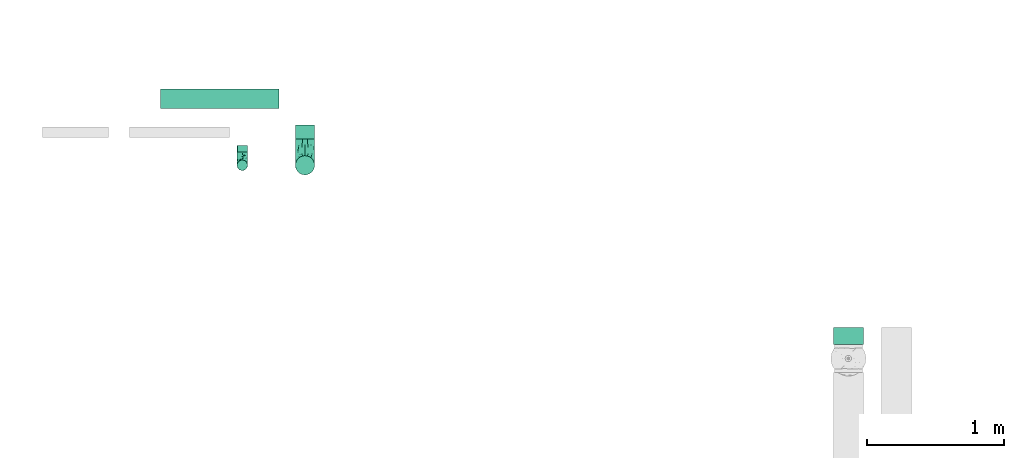
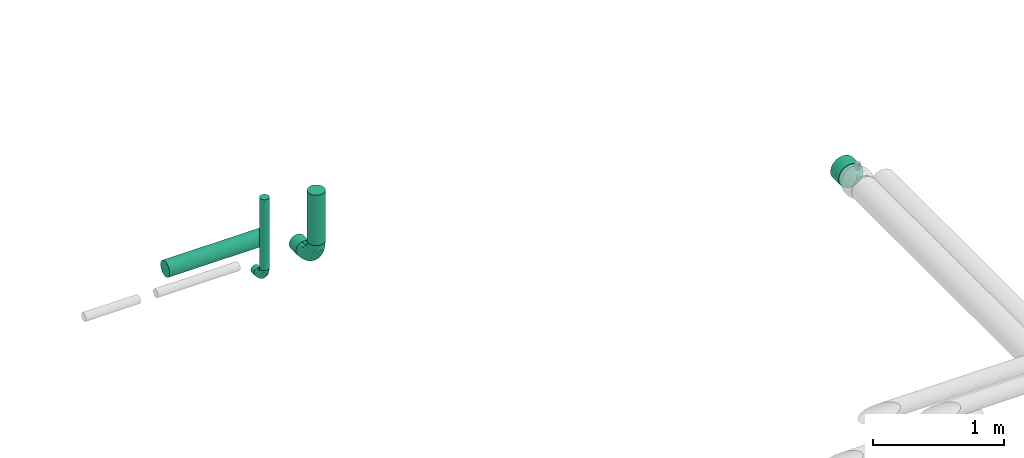
# One storey, part 2 of 6: 6 flow segments, 2 flow fittings.
"""IFC2X3 building model written with IfcOpenShell, lengths in millimetres."""

import ifcopenshell
import ifcopenshell.guid

model = None  # the IFC model being written
_history = None  # IfcOwnerHistory: only IFC2X3 demands one
_inside = {}  # id of a spatial element -> (the spatial element, [elements in it])
_under = {}  # id of a project, library or spatial element -> (it, [spatial elements below it])
_declared = {}  # id of a project -> (the project, [libraries it declares])
_typed = {}  # id of a type object -> (the type object, [elements of that type])
_made_of = {}  # id of a material, layer set ... -> (it, [elements and type objects made of it])


def new_model(schema):
    """Start an empty IFC model of exactly this schema.

    Asked for "IFC4X3", IfcOpenShell would pick the latest addendum, in which some entities
    have other attributes; the version numbers below select the first issue.
    IFC2X3 requires an IfcOwnerHistory on every rooted entity: one is made here for all.
    """
    global model, _history
    if schema == "IFC4X3":
        model = ifcopenshell.file(schema_version=(4, 3, 0, 0))
    else:
        model = ifcopenshell.file(schema=schema)
    _inside.clear()
    _under.clear()
    _declared.clear()
    _typed.clear()
    _made_of.clear()
    _history = None
    if model.schema == "IFC2X3":
        org = make("IfcOrganization", Name="unknown")
        user = make(
            "IfcPersonAndOrganization",
            ThePerson=make("IfcPerson", FamilyName="unknown"),
            TheOrganization=org,
        )
        app = make(
            "IfcApplication",
            ApplicationDeveloper=org,
            Version="unknown",
            ApplicationFullName="unknown",
            ApplicationIdentifier="unknown",
        )
        _history = make(
            "IfcOwnerHistory",
            OwningUser=user,
            OwningApplication=app,
            ChangeAction="ADDED",
            CreationDate=0,
        )
    return model


def make(cls, **values):
    """One entity of the class cls with the attributes given. An attribute that is None is left unset."""
    return model.create_entity(
        cls, **{name: value for name, value in values.items() if value is not None}
    )


def entity(cls, *values):
    """Any entity or typed value of the class cls, its attributes in the order of the schema. None: left unset."""
    e = model.create_entity(cls)
    for i, value in enumerate(values):
        if value is not None:
            e[i] = value
    return e


def rooted(cls, **values):
    """An entity with a GlobalId (a new one), such as an element, a storey or a relation."""
    return make(cls, GlobalId=ifcopenshell.guid.new(), OwnerHistory=_history, **values)


def si_unit(unit_type, name, prefix=None):
    """IfcSIUnit, for example si_unit("LENGTHUNIT", "METRE", prefix="MILLI")."""
    return make("IfcSIUnit", UnitType=unit_type, Prefix=prefix, Name=name)


def converted_unit(unit_type, name, factor, base, dimensions=None, offset=None):
    """IfcConversionBasedUnit, such as the inch: factor (a typed value) times the base unit."""
    return make(
        "IfcConversionBasedUnit"
        if offset is None
        else "IfcConversionBasedUnitWithOffset",
        ConversionOffset=offset,
        Dimensions=None
        if dimensions is None
        else entity("IfcDimensionalExponents", *dimensions),
        UnitType=unit_type,
        Name=name,
        ConversionFactor=make(
            "IfcMeasureWithUnit", ValueComponent=factor, UnitComponent=base
        ),
    )


def derived_unit(unit_type, elements):
    """IfcDerivedUnit: a product of units, each with its exponent."""
    return make(
        "IfcDerivedUnit",
        Elements=[
            make("IfcDerivedUnitElement", Unit=unit, Exponent=power)
            for unit, power in elements
        ],
        UnitType=unit_type,
    )


def assignment(units):
    """IfcUnitAssignment: the units of a project."""
    return None if units is None else make("IfcUnitAssignment", Units=units)


def point(xyz):
    """IfcCartesianPoint."""
    return None if xyz is None else make("IfcCartesianPoint", Coordinates=xyz)


def direction(xyz):
    """IfcDirection."""
    return None if xyz is None else make("IfcDirection", DirectionRatios=xyz)


def frame(location, z_axis=None, x_axis=None):
    """IfcAxis2Placement3D, a coordinate frame: its origin and axes. An axis left out is left unset."""
    return make(
        "IfcAxis2Placement3D",
        Location=point(location),
        Axis=direction(z_axis),
        RefDirection=direction(x_axis),
    )


def frame_2d(location, x_axis=None):
    """IfcAxis2Placement2D, a coordinate frame in the plane: its origin and x axis."""
    return make(
        "IfcAxis2Placement2D", Location=point(location), RefDirection=direction(x_axis)
    )


def origin():
    """The frame at (0, 0, 0) with its axes left unset."""
    return frame((0.0, 0.0, 0.0))


def origin_2d_with_axis():
    """The frame at (0, 0) in the plane with the x axis (1, 0) written out."""
    return frame_2d((0.0, 0.0), x_axis=(1.0, 0.0))


def place(relative_to, where):
    """IfcLocalPlacement: puts the frame where relative to a parent placement (None: the world)."""
    return make(
        "IfcLocalPlacement", PlacementRelTo=relative_to, RelativePlacement=where
    )


def context(
    kind, dimensions, precision=None, world=None, true_north=None, identifier=None
):
    """IfcGeometricRepresentationContext, for example the 3D "Model" context."""
    return make(
        "IfcGeometricRepresentationContext",
        ContextIdentifier=identifier,
        ContextType=kind,
        CoordinateSpaceDimension=dimensions,
        Precision=precision,
        WorldCoordinateSystem=world,
        TrueNorth=true_north,
    )


def subcontext(parent, identifier, kind, view, scale=None):
    """IfcGeometricRepresentationSubContext, for example "Body" below "Model"."""
    return make(
        "IfcGeometricRepresentationSubContext",
        ContextIdentifier=identifier,
        ContextType=kind,
        ParentContext=parent,
        TargetScale=scale,
        TargetView=view,
    )


def project(units=None, contexts=None):
    """IfcProject with its units and contexts."""
    return rooted(
        "IfcProject",
        Name="project",
        RepresentationContexts=contexts,
        UnitsInContext=assignment(units),
    )


def spatial(cls, under=None, at=None, **own):
    """A site, building, storey or space (cls), placed at a placement, below another one or the project."""
    s = rooted(cls, ObjectPlacement=at, **own)
    if under is not None:
        _under.setdefault(under.id(), (under, []))[1].append(s)
    return s


def polyline(points):
    """IfcPolyline through the points."""
    return make("IfcPolyline", Points=[point(p) for p in points])


def profile(cls, at=None, kind="AREA", **sizes):
    """A parametric profile (cls). Its sizes go by their IFC names, for example OverallWidth=200.0."""
    return make(cls, ProfileType=kind, Position=at, **sizes)


def circle(**sizes):
    """IfcCircleProfileDef."""
    return profile("IfcCircleProfileDef", **sizes)


def outline(outer, holes=None, kind="AREA"):
    """IfcArbitraryClosedProfileDef: a profile drawn as a closed curve; with holes, ...WithVoids."""
    if holes is None:
        return make("IfcArbitraryClosedProfileDef", ProfileType=kind, OuterCurve=outer)
    return make(
        "IfcArbitraryProfileDefWithVoids",
        ProfileType=kind,
        OuterCurve=outer,
        InnerCurves=holes,
    )


def extrude(swept, where, along, depth):
    """IfcExtrudedAreaSolid: the profile swept, set in the frame where, extruded along a direction by depth."""
    return make(
        "IfcExtrudedAreaSolid",
        SweptArea=swept,
        Position=where,
        ExtrudedDirection=direction(along),
        Depth=depth,
    )


def faces_of(points, faces, orient=None, outer=None):
    """IfcFace entities. A face is a list of loops; a loop is a list of indices into points, from 0.

    orient and outer hold one flag for each loop. By default every Orientation is true, the
    first loop of a face is its IfcFaceOuterBound and the others are IfcFaceBound.
    """
    made = []
    for i, loops in enumerate(faces):
        bounds = []
        for j, loop in enumerate(loops):
            is_outer = j == 0 if outer is None else outer[i][j]
            bounds.append(
                make(
                    "IfcFaceOuterBound" if is_outer else "IfcFaceBound",
                    Bound=make("IfcPolyLoop", Polygon=[points[k] for k in loop]),
                    Orientation=True if orient is None else orient[i][j],
                )
            )
        made.append(make("IfcFace", Bounds=bounds))
    return made


def faceted_brep(points, faces, orient=None, outer=None, voids=None):
    """IfcFacetedBrep: a solid bounded by flat faces; with voids (closed shells), ...WithVoids."""
    shared = [point(p) for p in points]
    hull = make("IfcClosedShell", CfsFaces=faces_of(shared, faces, orient, outer))
    if voids is None:
        return make("IfcFacetedBrep", Outer=hull)
    return make(
        "IfcFacetedBrepWithVoids",
        Outer=hull,
        Voids=[
            make(cls, CfsFaces=faces_of(shared, fs, o, b)) for cls, fs, o, b in voids
        ],
    )


def shape(context_of_items, identifier, shape_type, items):
    """IfcShapeRepresentation: the items that make up one representation, for example the "Body"."""
    return make(
        "IfcShapeRepresentation",
        ContextOfItems=context_of_items,
        RepresentationIdentifier=identifier,
        RepresentationType=shape_type,
        Items=items,
    )


def source(mapping_origin, context_of_items, identifier, shape_type, items):
    """IfcRepresentationMap: a shape defined once, which mapped items show again and again."""
    return make(
        "IfcRepresentationMap",
        MappingOrigin=mapping_origin,
        MappedRepresentation=shape(context_of_items, identifier, shape_type, items),
    )


def transform(
    local_origin,
    x_axis=None,
    y_axis=None,
    z_axis=None,
    scale=None,
    scale2=None,
    scale3=None,
    uniform=True,
):
    """IfcCartesianTransformationOperator3D, or its non-uniform kind. x_axis, y_axis, z_axis: its Axis1, 2, 3."""
    if uniform:
        return make(
            "IfcCartesianTransformationOperator3D",
            Axis1=direction(x_axis),
            Axis2=direction(y_axis),
            LocalOrigin=point(local_origin),
            Scale=scale,
            Axis3=direction(z_axis),
        )
    return make(
        "IfcCartesianTransformationOperator3DnonUniform",
        Axis1=direction(x_axis),
        Axis2=direction(y_axis),
        LocalOrigin=point(local_origin),
        Scale=scale,
        Axis3=direction(z_axis),
        Scale2=scale2,
        Scale3=scale3,
    )


def mapped(mapping_source, mapping_target):
    """IfcMappedItem: shows the shape of a source again, moved by a transform."""
    return make(
        "IfcMappedItem", MappingSource=mapping_source, MappingTarget=mapping_target
    )


def material(Name=None, Category=None):
    """IfcMaterial."""
    return make("IfcMaterial", Name=Name, Category=Category)


def made_of(thing, what):
    """Note that an element or type object is made of a material, layer set ...; save() writes the relation."""
    if what is not None:
        _made_of.setdefault(what.id(), (what, []))[1].append(thing)
    return thing


def type_object(cls, material=None, **own):
    """A type object (cls), such as IfcWallType, which elements share."""
    return made_of(rooted(cls, **own), material)


def type_shapes(of_type, sources):
    """Give a type object the sources (RepresentationMaps) that its elements show as mapped items."""
    of_type.RepresentationMaps = sources


def element(
    cls,
    number,
    at=None,
    inside=None,
    cuts=None,
    type_object=None,
    material=None,
    context=None,
    identifier="Body",
    shape_type=None,
    held_by="IfcProductDefinitionShape",
    body=None,
    shapes=None,
    **own,
):
    """One element of the class cls, such as IfcWall. Its Tag is "e" and its number.

    at: its placement. inside: the storey or other place that contains it. cuts: it is an
    opening in that element (IfcRelVoidsElement). A single representation is given by context,
    identifier, shape_type and body (its items); several are given by shapes. held_by: the class
    of the entity that holds the representations. save() writes the other relations.
    """
    e = rooted(cls, Tag="e%d" % number, ObjectPlacement=at, **own)
    if body is not None:
        shapes = [shape(context, identifier, shape_type, body)]
    if shapes is not None:
        e.Representation = make(held_by, Representations=shapes)
    if inside is not None:
        _inside.setdefault(inside.id(), (inside, []))[1].append(e)
    if cuts is not None:
        rooted(
            "IfcRelVoidsElement", RelatingBuildingElement=cuts, RelatedOpeningElement=e
        )
    if type_object is not None:
        _typed.setdefault(type_object.id(), (type_object, []))[1].append(e)
    return made_of(e, material)


def aggregate(whole, parts):
    """IfcRelAggregates: a whole, such as a stair, and the parts it consists of."""
    return rooted("IfcRelAggregates", RelatingObject=whole, RelatedObjects=parts)


def save(model, path):
    """Write the relations noted so far, then the file.

    IfcRelAggregates (storeys below a building ...), IfcRelContainedInSpatialStructure (elements
    in a storey), IfcRelDefinesByType, IfcRelAssociatesMaterial and IfcRelDeclares: one each for
    every whole, place, type object, material and project.
    """
    for whole, parts in _under.values():
        aggregate(whole, parts)
    for where, things in _inside.values():
        rooted(
            "IfcRelContainedInSpatialStructure",
            RelatedElements=things,
            RelatingStructure=where,
        )
    for kind, things in _typed.values():
        rooted("IfcRelDefinesByType", RelatedObjects=things, RelatingType=kind)
    for what, things in _made_of.values():
        rooted("IfcRelAssociatesMaterial", RelatedObjects=things, RelatingMaterial=what)
    for by, libraries in _declared.values():
        rooted("IfcRelDeclares", RelatingContext=by, RelatedDefinitions=libraries)
    model.write(path)


model = new_model("IFC2X3")

# Units and contexts
model_context = context("Model", 3, precision=0.01, world=origin(), true_north=direction((6.12303176911189e-17, 1.0)))
body_context = subcontext(model_context, "Body", "Model", "MODEL_VIEW")
ifc_project = project(units=[si_unit("LENGTHUNIT", "METRE", prefix="MILLI"), si_unit("AREAUNIT", "SQUARE_METRE"), si_unit("VOLUMEUNIT", "CUBIC_METRE"), converted_unit("PLANEANGLEUNIT", "DEGREE", entity("IfcRatioMeasure", 0.0174532925199433), si_unit("PLANEANGLEUNIT", "RADIAN"), dimensions=[0, 0, 0, 0, 0, 0, 0]), si_unit("MASSUNIT", "GRAM", prefix="KILO"), derived_unit("MASSDENSITYUNIT", [(si_unit("MASSUNIT", "GRAM", prefix="KILO"), 1), (si_unit("LENGTHUNIT", "METRE"), -3)]), derived_unit("MOMENTOFINERTIAUNIT", [(si_unit("LENGTHUNIT", "METRE"), 4)]), si_unit("TIMEUNIT", "SECOND"), si_unit("FREQUENCYUNIT", "HERTZ"), si_unit("THERMODYNAMICTEMPERATUREUNIT", "DEGREE_CELSIUS"), derived_unit("THERMALTRANSMITTANCEUNIT", [(si_unit("MASSUNIT", "GRAM", prefix="KILO"), 1), (si_unit("THERMODYNAMICTEMPERATUREUNIT", "KELVIN"), -1), (si_unit("TIMEUNIT", "SECOND"), -3)]), derived_unit("VOLUMETRICFLOWRATEUNIT", [(si_unit("LENGTHUNIT", "METRE"), 3), (si_unit("TIMEUNIT", "SECOND"), -1)]), derived_unit("MASSFLOWRATEUNIT", [(si_unit("MASSUNIT", "GRAM", prefix="KILO"), 1), (si_unit("TIMEUNIT", "SECOND"), -1)]), derived_unit("ROTATIONALFREQUENCYUNIT", [(si_unit("TIMEUNIT", "SECOND"), -1)]), si_unit("ELECTRICCURRENTUNIT", "AMPERE"), si_unit("ELECTRICVOLTAGEUNIT", "VOLT"), si_unit("POWERUNIT", "WATT"), si_unit("FORCEUNIT", "NEWTON", prefix="KILO"), si_unit("ILLUMINANCEUNIT", "LUX"), si_unit("LUMINOUSFLUXUNIT", "LUMEN"), si_unit("LUMINOUSINTENSITYUNIT", "CANDELA"), derived_unit("USERDEFINED", [(si_unit("MASSUNIT", "GRAM", prefix="KILO"), -1), (si_unit("LENGTHUNIT", "METRE"), -2), (si_unit("TIMEUNIT", "SECOND"), 3), (si_unit("LUMINOUSFLUXUNIT", "LUMEN"), 1)]), derived_unit("LINEARVELOCITYUNIT", [(si_unit("LENGTHUNIT", "METRE"), 1), (si_unit("TIMEUNIT", "SECOND"), -1)]), si_unit("PRESSUREUNIT", "PASCAL"), derived_unit("USERDEFINED", [(si_unit("LENGTHUNIT", "METRE"), -2), (si_unit("MASSUNIT", "GRAM", prefix="KILO"), 1), (si_unit("TIMEUNIT", "SECOND"), -2)]), derived_unit("LINEARFORCEUNIT", [(si_unit("MASSUNIT", "GRAM", prefix="KILO"), 1), (si_unit("LENGTHUNIT", "METRE"), 1), (si_unit("TIMEUNIT", "SECOND"), -2), (si_unit("LENGTHUNIT", "METRE"), -1)]), derived_unit("PLANARFORCEUNIT", [(si_unit("MASSUNIT", "GRAM", prefix="KILO"), 1), (si_unit("LENGTHUNIT", "METRE"), 1), (si_unit("TIMEUNIT", "SECOND"), -2), (si_unit("LENGTHUNIT", "METRE"), -2)])], contexts=[model_context])

# Site, building, storey
site_placement = place(None, origin())
site = spatial("IfcSite", under=ifc_project, at=site_placement, CompositionType="ELEMENT")
building_placement = place(site_placement, origin())
building = spatial("IfcBuilding", under=site, at=building_placement, CompositionType="ELEMENT")
storey_placement = place(building_placement, origin())
storey = spatial("IfcBuildingStorey", under=building, at=storey_placement, Name="01", CompositionType="ELEMENT", Elevation=0.0)

# Flow segments
pipe_segment_type_1 = type_object("IfcPipeSegmentType", PredefinedType="NOTDEFINED")
flow_segment_1_placement = place(storey_placement, frame((30968.9, 10524.83, 30888.9)))
element("IfcFlowSegment", 1, at=flow_segment_1_placement, inside=storey, type_object=pipe_segment_type_1, context=body_context, shape_type="SweptSolid", body=[
    extrude(outline(polyline([(-14.29, -108.56), (14.29, -108.56), (41.9, -101.16), (66.66, -86.87), (86.87, -66.66), (101.16, -41.9), (108.56, -14.29), (108.56, 14.29), (101.16, 41.9), (86.87, 66.66), (66.66, 86.87), (41.9, 101.16), (14.29, 108.56), (-14.29, 108.56), (-41.9, 101.16), (-66.66, 86.87), (-86.87, 66.66), (-101.16, 41.9), (-108.56, 14.29), (-108.56, -14.29), (-101.16, -41.9), (-86.87, -66.66), (-66.66, -86.87), (-41.9, -101.16), (-14.29, -108.56)])), frame((111.1, 0.0, 111.1), z_axis=(3.15699485387893e-09, 1.0, 0.0), x_axis=(0.130526192220095, 0.0, 0.991444861373805)), (0.0, 0.0, 1.0), 125.173920988328),
])
pipe_segment_type_2 = type_object("IfcPipeSegmentType", PredefinedType="NOTDEFINED")
flow_segment_2_placement = place(storey_placement, frame((26068.17, 12243.97, 30728.4)))
element("IfcFlowSegment", 2, at=flow_segment_2_placement, inside=storey, type_object=pipe_segment_type_2, context=body_context, shape_type="SweptSolid", body=[
    extrude(circle(Radius=70.0, at=origin_2d_with_axis()), frame((0.0, 71.6, 71.6), z_axis=(1.0, 0.0, 0.0), x_axis=(0.0, -1.0, 0.0)), (0.0, 0.0, 1.0), 862.1589957244),
])
flow_segment_3_placement = place(storey_placement, frame((26624.29, 11925.46, 30760.65)))
element("IfcFlowSegment", 3, at=flow_segment_3_placement, inside=storey, type_object=pipe_segment_type_2, context=body_context, shape_type="SweptSolid", body=[
    extrude(circle(Radius=37.75, at=origin_2d_with_axis()), frame((39.35, 0.0, 39.35), z_axis=(0.0, 1.0, 0.0), x_axis=(-1.0, 0.0, 0.0)), (0.0, 0.0, 1.0), 49.545929764131),
])
flow_segment_4_placement = place(storey_placement, frame((27048.74, 12020.46, 30728.4)))
element("IfcFlowSegment", 4, at=flow_segment_4_placement, inside=storey, type_object=pipe_segment_type_2, context=body_context, shape_type="SweptSolid", body=[
    extrude(circle(Radius=70.0, at=origin_2d_with_axis()), frame((71.6, 0.0, 71.6), z_axis=(0.0, 1.0, 0.0), x_axis=(-1.0, 0.0, 0.0)), (0.0, 0.0, 1.0), 105.109421625168),
])
flow_segment_5_placement = place(storey_placement, frame((27048.74, 11758.86, 30990.0)))
element("IfcFlowSegment", 5, at=flow_segment_5_placement, inside=storey, type_object=pipe_segment_type_2, context=body_context, shape_type="SweptSolid", body=[
    extrude(circle(Radius=70.0, at=origin_2d_with_axis()), frame((71.6, 71.6, 0.0)), (0.0, 0.0, 1.0), 470.000000000014),
])
flow_segment_6_placement = place(storey_placement, frame((26624.29, 11791.11, 30895.0)))
element("IfcFlowSegment", 6, at=flow_segment_6_placement, inside=storey, type_object=pipe_segment_type_2, context=body_context, shape_type="SweptSolid", body=[
    extrude(circle(Radius=37.75, at=origin_2d_with_axis()), frame((39.35, 39.35, 0.0)), (0.0, 0.0, 1.0), 660.00000000001),
])

# Flow fittings
ifc_material = material()
pipe_fitting_type_1 = type_object("IfcPipeFittingType", Name="ADSK_1", PredefinedType="NOTDEFINED", material=ifc_material)
shared_shape_1 = source(origin(), body_context, "Body", "Brep", [
    faceted_brep([(-95.0, 19.02, -32.95), (-95.0, 9.85, -36.75), (-95.0, 0.0, -38.05), (-95.0, -9.85, -36.75), (-95.0, -19.03, -32.95), (-95.0, -26.91, -26.91), (-95.0, -32.95, -19.03), (-95.0, -36.75, -9.85), (-95.0, -38.05, 0.0), (-95.0, -36.75, 9.85), (-95.0, -32.95, 19.02), (-95.0, -26.91, 26.91), (-95.0, -19.03, 32.95), (-95.0, -9.85, 36.75), (-95.0, 0.0, 38.05), (-95.0, 9.85, 36.75), (-95.0, 19.02, 32.95), (-95.0, 26.91, 26.91), (-95.0, 32.95, 19.02), (-95.0, 36.75, 9.85), (-95.0, 38.05, 0.0), (-95.0, 36.75, -9.85), (-95.0, 32.95, -19.03), (-95.0, 26.91, -26.91), (0.0, 95.0, -38.05), (-9.85, 95.0, -36.75), (-19.02, 95.0, -32.95), (-26.91, 95.0, -26.91), (-32.95, 95.0, -19.03), (-36.75, 95.0, -9.85), (-38.05, 95.0, 0.0), (-36.75, 95.0, 9.85), (-32.95, 95.0, 19.02), (-26.91, 95.0, 26.91), (-19.02, 95.0, 32.95), (-9.85, 95.0, 36.75), (0.0, 95.0, 38.05), (9.85, 95.0, 36.75), (19.03, 95.0, 32.95), (26.91, 95.0, 26.91), (32.95, 95.0, 19.02), (36.75, 95.0, 9.85), (38.05, 95.0, 0.0), (36.75, 95.0, -9.85), (32.95, 95.0, -19.03), (26.91, 95.0, -26.91), (19.03, 95.0, -32.95), (9.85, 95.0, -36.75), (-7.99, -4.96, 6.3), (-0.92, 0.92, 0.0), (4.62, 8.1, 8.01), (-76.19, -35.57, 0.0), (-64.32, -32.32, 12.43), (20.51, 62.45, 28.68), (-60.56, -33.52, 0.0), (-70.4, -13.47, 34.42), (-39.61, -5.88, 32.32), (-49.6, 2.07, 37.1), (-70.34, -28.81, 21.71), (14.64, 40.81, 26.5), (5.88, 39.61, 32.32), (3.59, 20.77, 25.31), (-40.45, 68.06, 16.75), (-62.45, -20.51, 28.68), (-44.52, -26.87, 0.0), (-28.47, -20.22, 0.0), (-26.43, -17.83, 8.75), (-76.1, 39.63, 10.76), (-72.74, 37.58, 18.19), (-60.35, 46.18, 14.61), (-13.4, 13.4, 32.12), (-20.77, -3.59, 25.31), (-14.66, 81.47, 35.56), (-6.22, 71.26, 37.92), (-57.5, 42.48, 22.79), (-15.0, 34.74, 37.7), (-27.1, 12.08, 36.05), (-9.2, 28.81, 35.63), (-79.98, 23.7, 30.95), (-73.68, -4.3, 37.48), (-30.74, 21.67, 37.97), (-62.36, 47.59, 6.79), (-72.71, 32.83, 24.69), (-67.42, 7.02, 37.95), (-32.13, 75.27, 24.51), (-43.46, 51.47, 26.26), (-24.98, 73.15, 31.29), (20.59, 41.28, 19.85), (7.79, 16.09, 15.86), (-73.21, 42.39, 0.0), (-54.73, 54.73, 0.0), (-73.44, 15.79, 35.79), (-5.94, 4.32, 20.43), (28.81, 70.34, 21.71), (32.32, 64.32, 12.43), (-53.59, 26.2, 35.09), (-52.02, 19.31, 37.21), (21.38, 33.53, 10.34), (26.87, 44.52, 0.0), (-48.28, 12.14, 38.05), (4.3, 73.68, 37.48), (-44.08, -25.52, 12.79), (-41.28, -20.59, 19.85), (35.57, 76.19, 0.0), (-47.26, 54.3, 20.18), (-47.4, 61.99, 8.58), (-42.39, 73.21, 0.0), (-39.67, 78.86, 7.21), (-45.69, 36.84, 33.11), (-32.83, 50.13, 33.35), (13.47, 70.4, 34.42), (-18.25, 63.73, 36.07), (-40.63, -13.75, 27.22), (-16.63, 46.37, 37.95), (-53.47, 38.79, 28.59), (-26.07, 48.54, 36.15), (-34.51, 34.51, 36.86), (-2.07, 49.6, 37.1), (-22.79, -10.49, 19.23), (-61.73, 28.67, 31.87), (9.65, 14.7, 0.0), (20.22, 28.47, 0.0), (33.52, 60.56, 0.0), (-11.42, -5.44, 13.25), (-14.7, -9.65, 0.0), (-81.47, 14.66, -35.56), (-62.45, -20.51, -28.68), (-71.26, 6.22, -37.92), (-75.27, 32.13, -24.51), (-73.15, 24.98, -31.29), (13.47, 70.4, -34.42), (5.88, 39.61, -32.32), (-2.07, 49.6, -37.1), (-78.86, 39.67, -7.21), (-70.4, -13.47, -34.42), (-39.61, -5.88, -32.32), (-61.99, 47.4, -8.58), (32.32, 64.32, -12.43), (28.81, 70.34, -21.71), (-63.73, 18.25, -36.07), (-50.13, 32.83, -33.35), (4.3, 73.68, -37.48), (-7.02, 67.42, -37.95), (-39.63, 76.1, -10.76), (-46.18, 60.35, -14.61), (-47.59, 62.36, -6.79), (-64.32, -32.32, -12.43), (-26.2, 53.59, -35.09), (-15.79, 73.44, -35.79), (-19.31, 52.02, -37.21), (-37.58, 72.74, -18.19), (-70.34, -28.81, -21.71), (-42.48, 57.5, -22.79), (-38.79, 53.47, -28.59), (-51.47, 43.46, -26.26), (-32.83, 72.71, -24.69), (-46.37, 16.63, -37.95), (-73.68, -4.3, -37.48), (-41.28, -20.59, -19.85), (-44.08, -25.52, -12.79), (13.75, 40.63, -27.22), (20.51, 62.45, -28.68), (-68.06, 40.45, -16.75), (-54.3, 47.26, -20.18), (-12.14, 48.28, -38.05), (-21.67, 30.74, -37.97), (-36.84, 45.69, -33.11), (-11.42, -5.44, -13.25), (7.79, 16.09, -15.86), (4.62, 8.1, -8.01), (-23.7, 79.98, -30.95), (-26.43, -17.83, -8.75), (-7.99, -4.96, -6.3), (-40.81, -14.64, -26.5), (-20.77, -3.59, -25.31), (-34.74, 15.0, -37.7), (-12.08, 27.1, -36.05), (-28.81, 9.2, -35.63), (-22.79, -10.49, -19.23), (21.38, 33.53, -10.34), (20.59, 41.28, -19.85), (-48.54, 26.07, -36.15), (-49.6, 2.07, -37.1), (-13.4, 13.4, -32.12), (3.59, 20.77, -25.31), (-28.67, 61.73, -31.87), (-34.51, 34.51, -36.86), (-5.94, 4.32, -20.43)], [[[0, 1, 2, 3, 4, 5, 6, 7, 8, 9, 10, 11, 12, 13, 14, 15, 16, 17, 18, 19, 20, 21, 22, 23]], [[24, 25, 26, 27, 28, 29, 30, 31, 32, 33, 34, 35, 36, 37, 38, 39, 40, 41, 42, 43, 44, 45, 46, 47]], [[48, 49, 50]], [[51, 52, 9]], [[53, 39, 38]], [[9, 52, 10]], [[54, 52, 51]], [[55, 56, 57]], [[11, 10, 58]], [[59, 60, 61]], [[32, 31, 62]], [[63, 12, 11]], [[63, 55, 12]], [[64, 65, 66]], [[67, 68, 69]], [[70, 56, 71]], [[35, 72, 73]], [[69, 68, 74]], [[75, 76, 77]], [[16, 78, 17]], [[13, 79, 14]], [[76, 75, 80]], [[67, 69, 81]], [[18, 17, 82]], [[14, 79, 83]], [[20, 19, 67]], [[84, 85, 86]], [[87, 61, 88]], [[89, 81, 90]], [[18, 82, 68]], [[15, 91, 16]], [[14, 83, 15]], [[71, 92, 61]], [[17, 78, 82]], [[93, 87, 94]], [[95, 91, 96]], [[97, 98, 94]], [[86, 72, 34]], [[96, 99, 80]], [[37, 36, 100]], [[40, 39, 93]], [[40, 94, 41]], [[64, 66, 101]], [[93, 94, 40]], [[58, 102, 63]], [[94, 103, 41]], [[94, 87, 97]], [[104, 69, 74]], [[34, 33, 86]], [[105, 69, 104]], [[52, 58, 10]], [[106, 107, 30]], [[108, 109, 85]], [[105, 106, 90]], [[53, 110, 60]], [[86, 111, 72]], [[86, 109, 111]], [[33, 84, 86]], [[12, 55, 13]], [[112, 56, 63]], [[110, 38, 37]], [[34, 72, 35]], [[36, 35, 73]], [[111, 113, 73]], [[105, 107, 106]], [[110, 53, 38]], [[74, 114, 85]], [[91, 15, 83]], [[105, 90, 81]], [[107, 62, 31]], [[33, 32, 84]], [[115, 109, 116]], [[111, 115, 113]], [[100, 73, 117]], [[56, 55, 63]], [[79, 55, 57]], [[102, 118, 112]], [[56, 70, 76]], [[100, 110, 37]], [[117, 77, 60]], [[117, 60, 110]], [[60, 70, 61]], [[58, 52, 101]], [[63, 11, 58]], [[39, 53, 93]], [[87, 93, 53]], [[96, 91, 83]], [[78, 91, 119]], [[32, 62, 84]], [[84, 62, 104]], [[86, 85, 109]], [[85, 114, 108]], [[80, 113, 116]], [[117, 73, 113]], [[80, 116, 96]], [[80, 57, 76]], [[71, 112, 118]], [[61, 87, 59]], [[62, 107, 105]], [[97, 120, 121]], [[70, 71, 61]], [[71, 118, 92]], [[73, 100, 36]], [[110, 100, 117]], [[55, 79, 13]], [[83, 79, 57]], [[96, 83, 99]], [[116, 108, 95]], [[50, 97, 88]], [[97, 87, 88]], [[50, 49, 120]], [[122, 94, 98]], [[89, 20, 67]], [[105, 81, 69]], [[89, 67, 81]], [[68, 19, 18]], [[68, 67, 19]], [[74, 68, 82]], [[114, 82, 119]], [[74, 85, 104]], [[82, 114, 74]], [[114, 119, 108]], [[95, 108, 119]], [[116, 109, 108]], [[123, 48, 50]], [[97, 50, 120]], [[123, 50, 88]], [[91, 95, 119]], [[116, 95, 96]], [[84, 104, 85]], [[104, 62, 105]], [[83, 57, 99]], [[57, 80, 99]], [[66, 48, 123]], [[66, 124, 48]], [[118, 66, 123]], [[124, 66, 65]], [[66, 118, 101]], [[54, 64, 52]], [[124, 49, 48]], [[30, 107, 31]], [[91, 78, 16]], [[82, 78, 119]], [[56, 76, 57]], [[77, 76, 70]], [[60, 77, 70]], [[77, 117, 75]], [[117, 113, 75]], [[113, 80, 75]], [[9, 8, 51]], [[103, 94, 122]], [[103, 42, 41]], [[73, 72, 111]], [[113, 115, 116]], [[111, 109, 115]], [[102, 112, 63]], [[71, 56, 112]], [[118, 102, 101]], [[92, 123, 88]], [[123, 92, 118]], [[61, 92, 88]], [[87, 53, 59]], [[60, 59, 53]], [[97, 121, 98]], [[58, 101, 102]], [[64, 101, 52]], [[125, 1, 0]], [[126, 5, 4]], [[2, 1, 127]], [[1, 125, 127]], [[128, 129, 23]], [[130, 131, 132]], [[89, 133, 20]], [[126, 134, 135]], [[136, 89, 90]], [[137, 138, 44]], [[139, 129, 140]], [[24, 141, 142]], [[143, 144, 145]], [[125, 129, 139]], [[6, 146, 7]], [[147, 148, 149]], [[146, 51, 7]], [[143, 150, 144]], [[146, 6, 151]], [[152, 153, 154]], [[126, 4, 134]], [[0, 23, 129]], [[28, 155, 150]], [[43, 42, 103]], [[54, 146, 64]], [[139, 156, 127]], [[157, 3, 2]], [[151, 158, 159]], [[160, 131, 161]], [[22, 21, 162]], [[136, 144, 163]], [[149, 164, 165]], [[24, 142, 25]], [[166, 140, 154]], [[154, 129, 128]], [[143, 30, 29]], [[167, 168, 169]], [[155, 28, 27]], [[26, 170, 27]], [[171, 167, 172]], [[26, 25, 148]], [[27, 170, 155]], [[173, 135, 174]], [[144, 150, 152]], [[175, 176, 177]], [[24, 47, 141]], [[45, 161, 46]], [[148, 25, 142]], [[176, 175, 165]], [[64, 159, 171]], [[138, 45, 44]], [[130, 46, 161]], [[137, 44, 43]], [[178, 159, 158]], [[137, 103, 122]], [[163, 144, 152]], [[136, 133, 89]], [[103, 137, 43]], [[6, 5, 151]], [[178, 158, 173]], [[134, 4, 3]], [[178, 173, 174]], [[137, 98, 179]], [[145, 90, 106]], [[138, 180, 161]], [[46, 130, 47]], [[136, 90, 145]], [[133, 162, 21]], [[23, 22, 128]], [[139, 140, 181]], [[139, 181, 156]], [[157, 127, 182]], [[157, 134, 3]], [[182, 177, 135]], [[182, 135, 134]], [[135, 183, 174]], [[131, 130, 161]], [[141, 130, 132]], [[160, 180, 184]], [[131, 183, 176]], [[5, 126, 151]], [[158, 151, 126]], [[180, 138, 137]], [[161, 45, 138]], [[149, 148, 142]], [[170, 148, 185]], [[22, 162, 128]], [[128, 162, 163]], [[129, 154, 140]], [[154, 153, 166]], [[165, 156, 186]], [[182, 127, 156]], [[165, 186, 149]], [[165, 132, 176]], [[131, 184, 183]], [[187, 167, 178]], [[184, 168, 187]], [[167, 169, 172]], [[184, 180, 168]], [[174, 183, 184]], [[127, 157, 2]], [[134, 157, 182]], [[130, 141, 47]], [[142, 141, 132]], [[149, 142, 164]], [[186, 166, 147]], [[180, 179, 168]], [[169, 179, 120]], [[137, 179, 180]], [[179, 121, 120]], [[106, 30, 143]], [[136, 145, 144]], [[106, 143, 145]], [[150, 29, 28]], [[150, 143, 29]], [[152, 150, 155]], [[153, 155, 185]], [[152, 154, 163]], [[155, 153, 152]], [[153, 185, 166]], [[147, 166, 185]], [[186, 140, 166]], [[169, 120, 49]], [[169, 49, 172]], [[179, 169, 168]], [[148, 147, 185]], [[186, 147, 149]], [[128, 163, 154]], [[163, 162, 136]], [[142, 132, 164]], [[132, 165, 164]], [[171, 124, 65]], [[124, 171, 172]], [[64, 146, 159]], [[171, 159, 178]], [[171, 65, 64]], [[172, 49, 124]], [[162, 133, 136]], [[20, 133, 21]], [[148, 170, 26]], [[155, 170, 185]], [[131, 176, 132]], [[177, 176, 183]], [[135, 177, 183]], [[177, 182, 175]], [[182, 156, 175]], [[156, 165, 175]], [[51, 146, 54]], [[51, 8, 7]], [[129, 125, 0]], [[127, 125, 139]], [[140, 186, 181]], [[156, 181, 186]], [[158, 126, 173]], [[135, 173, 126]], [[187, 178, 174]], [[171, 178, 167]], [[184, 187, 174]], [[167, 187, 168]], [[180, 160, 161]], [[184, 131, 160]], [[98, 137, 122]], [[98, 121, 179]], [[151, 159, 146]]]),
])
type_shapes(pipe_fitting_type_1, [shared_shape_1])
flow_fitting_1_placement = place(storey_placement, frame((26663.64, 11830.46, 30800.0), z_axis=(-1.0, 0.0, 0.0), x_axis=(0.0, -1.0, 0.0)))
element("IfcFlowFitting", 7, at=flow_fitting_1_placement, inside=storey, type_object=pipe_fitting_type_1, material=ifc_material, Name="ADSK_1", ObjectType="ADSK_1", context=body_context, shape_type="MappedRepresentation", body=[
    mapped(shared_shape_1, transform((0.0, 0.0, 0.0), scale=1.0)),
])
pipe_fitting_type_2 = type_object("IfcPipeFittingType", Name="ADSK_1", PredefinedType="NOTDEFINED", material=ifc_material)
shared_shape_2 = source(origin(), body_context, "Body", "Brep", [
    faceted_brep([(-190.0, 18.08, -67.47), (-190.0, 0.0, -69.85), (-190.0, -18.08, -67.47), (-190.0, -34.93, -60.49), (-190.0, -49.39, -49.39), (-190.0, -60.49, -34.93), (-190.0, -67.47, -18.08), (-190.0, -69.85, 0.0), (-190.0, -67.47, 18.08), (-190.0, -60.49, 34.92), (-190.0, -49.39, 49.39), (-190.0, -34.93, 60.49), (-190.0, -18.08, 67.47), (-190.0, 0.0, 69.85), (-190.0, 18.08, 67.47), (-190.0, 34.92, 60.49), (-190.0, 49.39, 49.39), (-190.0, 60.49, 34.92), (-190.0, 67.47, 18.08), (-190.0, 69.85, 0.0), (-190.0, 67.47, -18.08), (-190.0, 60.49, -34.93), (-190.0, 49.39, -49.39), (-190.0, 34.92, -60.49), (18.08, 190.0, -67.47), (0.0, 190.0, -69.85), (-18.08, 190.0, -67.47), (-34.92, 190.0, -60.49), (-49.39, 190.0, -49.39), (-60.49, 190.0, -34.93), (-67.47, 190.0, -18.08), (-69.85, 190.0, 0.0), (-67.47, 190.0, 18.08), (-60.49, 190.0, 34.92), (-49.39, 190.0, 49.39), (-34.92, 190.0, 60.49), (-18.08, 190.0, 67.47), (0.0, 190.0, 69.85), (18.08, 190.0, 67.47), (34.93, 190.0, 60.49), (49.39, 190.0, 49.39), (60.49, 190.0, 34.92), (67.47, 190.0, 18.08), (69.85, 190.0, 0.0), (67.47, 190.0, -18.08), (60.49, 190.0, -34.93), (49.39, 190.0, -49.39), (34.93, 190.0, -60.49), (-29.62, 146.98, 65.62), (-13.75, 135.37, 69.64), (-124.22, -36.33, 52.83), (-140.23, -52.18, 40.04), (-80.56, -34.09, 36.78), (-140.97, -24.01, 63.29), (-80.93, -8.05, 59.8), (-100.59, 5.62, 68.24), (-125.19, -57.65, 22.9), (-139.31, -64.86, 0.0), (-28.7, -8.91, 22.6), (-45.64, -26.06, 0.0), (-6.26, 6.26, 0.0), (-105.44, 36.89, 68.2), (-118.83, 43.56, 64.34), (-146.98, 29.62, 65.62), (-71.47, -38.86, 17.07), (-90.56, -50.07, 0.0), (-0.6, 27.02, 35.97), (-44.76, -2.31, 47.74), (-42.86, -12.1, 35.78), (-148.03, -7.38, 68.85), (-135.37, 13.75, 69.64), (-67.48, 159.11, 28.79), (36.32, 124.15, 52.82), (-38.8, 102.11, 68.2), (-24.59, 96.61, 69.85), (-81.73, 130.22, 21.92), (-65.15, 30.31, 68.68), (-27.72, 54.52, 66.49), (-44.98, 61.25, 69.74), (-75.73, 152.87, 0.0), (-159.11, 67.48, 28.79), (-130.22, 81.73, 21.92), (-152.87, 75.73, 0.0), (-76.65, 126.59, 35.57), (-101.51, 101.51, 25.92), (-96.74, 96.74, 38.75), (-144.94, 60.97, 45.11), (-159.57, 43.91, 56.71), (-119.38, 92.8, 0.0), (50.07, 90.56, 0.0), (57.42, 124.25, 22.84), (38.8, 71.6, 17.49), (64.86, 139.31, 0.0), (52.17, 140.21, 40.03), (33.37, 79.39, 36.99), (24.0, 140.95, 63.29), (8.03, 80.92, 59.81), (-82.61, -22.17, 50.94), (7.38, 148.03, 68.85), (-100.26, 79.14, 51.33), (-75.76, 96.1, 55.72), (-76.12, 111.95, 46.7), (-92.8, 119.38, 0.0), (-104.27, 104.27, 12.31), (10.07, 27.17, 16.15), (26.06, 45.64, 0.0), (-61.21, 144.14, 45.16), (-44.13, 158.15, 56.77), (-55.26, 120.41, 58.38), (9.95, 57.03, 48.64), (29.48, 90.08, 47.56), (-5.62, 100.59, 68.24), (-122.78, 54.24, 58.28), (-86.25, 73.26, 61.12), (-95.79, 24.47, 69.85), (-126.59, 76.65, 35.57), (-17.15, 26.56, 50.85), (-29.82, 29.82, 59.54), (-70.73, 11.02, 65.19), (-58.6, 94.58, 64.16), (-71.14, 66.1, 67.41), (-158.15, 44.13, -56.77), (33.37, 79.39, -36.99), (10.07, 27.17, -16.15), (-0.6, 27.02, -35.97), (-100.59, 5.62, -68.24), (-148.03, -7.38, -68.85), (-135.37, 13.75, -69.64), (-130.22, 81.73, -21.92), (-146.98, 29.62, -65.62), (-102.11, 38.8, -68.2), (-96.61, 24.59, -69.85), (-83.02, -24.86, -48.76), (-44.76, -2.31, -47.74), (-80.56, -34.09, -36.78), (-122.68, -57.24, -22.15), (-71.43, -38.87, -16.95), (-104.27, 104.27, -12.31), (-159.11, 67.48, -28.79), (-144.14, 61.21, -45.16), (7.38, 148.03, -68.85), (-13.75, 135.37, -69.64), (-79.14, 100.26, -51.33), (-96.1, 75.76, -55.72), (-111.95, 76.12, -46.7), (-80.93, -8.05, -59.8), (-124.22, -36.33, -52.83), (-140.23, -52.18, -40.04), (-24.47, 95.79, -69.85), (-36.89, 105.44, -68.2), (-150.18, -65.36, -13.92), (-43.56, 118.83, -64.34), (-29.62, 146.98, -65.62), (38.8, 71.6, -17.49), (-81.73, 130.22, -21.92), (-28.7, -8.91, -22.6), (-54.24, 122.78, -58.28), (-73.26, 86.25, -61.12), (-61.25, 44.98, -69.74), (-30.31, 65.15, -68.68), (-54.52, 27.72, -66.49), (-101.51, 101.51, -25.92), (-126.59, 76.65, -35.57), (-96.74, 96.74, -38.75), (-67.48, 159.11, -28.79), (-120.41, 55.26, -58.38), (-43.91, 159.57, -56.71), (24.0, 140.95, -63.29), (8.03, 80.92, -59.81), (-5.62, 100.59, -68.24), (-60.97, 144.94, -45.11), (36.32, 124.15, -52.82), (57.42, 124.25, -22.84), (52.17, 140.21, -40.03), (-140.97, -24.01, -63.29), (9.95, 57.03, -48.64), (-76.65, 126.59, -35.57), (22.84, 89.04, -52.94), (-11.03, 70.74, -65.2), (-29.82, 29.82, -59.54), (-94.58, 58.6, -64.16), (-66.1, 71.14, -67.41), (-31.42, -3.01, -36.09), (-13.88, 24.32, -46.86)], [[[0, 1, 2, 3, 4, 5, 6, 7, 8, 9, 10, 11, 12, 13, 14, 15, 16, 17, 18, 19, 20, 21, 22, 23]], [[24, 25, 26, 27, 28, 29, 30, 31, 32, 33, 34, 35, 36, 37, 38, 39, 40, 41, 42, 43, 44, 45, 46, 47]], [[36, 48, 49]], [[50, 51, 52]], [[53, 54, 55]], [[56, 9, 8]], [[8, 7, 57]], [[58, 59, 60]], [[51, 9, 56]], [[61, 62, 63]], [[59, 58, 64]], [[59, 64, 65]], [[11, 10, 50]], [[66, 67, 68]], [[50, 53, 11]], [[69, 70, 13]], [[71, 33, 32]], [[72, 40, 39]], [[73, 74, 49]], [[63, 15, 14]], [[13, 70, 14]], [[71, 32, 75]], [[12, 69, 13]], [[76, 77, 78]], [[32, 79, 75]], [[18, 80, 81]], [[63, 14, 70]], [[82, 19, 18]], [[83, 84, 85]], [[86, 16, 87]], [[82, 81, 88]], [[82, 18, 81]], [[15, 87, 16]], [[83, 71, 75]], [[52, 56, 64]], [[49, 37, 36]], [[89, 90, 91]], [[36, 35, 48]], [[42, 41, 90]], [[89, 92, 90]], [[11, 53, 12]], [[73, 78, 74]], [[65, 56, 57]], [[40, 72, 93]], [[94, 90, 93]], [[41, 40, 93]], [[72, 95, 96]], [[95, 39, 38]], [[8, 57, 56]], [[43, 42, 92]], [[67, 54, 97]], [[38, 37, 98]], [[99, 100, 101]], [[102, 75, 79]], [[51, 10, 9]], [[102, 88, 103]], [[31, 79, 32]], [[104, 60, 105]], [[106, 34, 33]], [[84, 103, 81]], [[91, 105, 89]], [[107, 35, 34]], [[106, 108, 107]], [[49, 48, 73]], [[104, 105, 91]], [[16, 86, 17]], [[58, 104, 66]], [[109, 110, 96]], [[111, 98, 49]], [[112, 113, 99]], [[92, 42, 90]], [[95, 72, 39]], [[70, 114, 61]], [[80, 18, 17]], [[101, 106, 83]], [[99, 86, 112]], [[115, 81, 80]], [[90, 94, 91]], [[94, 66, 104]], [[64, 58, 68]], [[56, 65, 64]], [[93, 72, 110]], [[90, 41, 93]], [[98, 95, 38]], [[111, 77, 96]], [[111, 96, 95]], [[67, 116, 117]], [[52, 51, 56]], [[50, 10, 51]], [[54, 53, 50]], [[69, 53, 55]], [[97, 52, 67]], [[118, 76, 55]], [[107, 48, 35]], [[73, 119, 120]], [[61, 63, 70]], [[63, 62, 87]], [[94, 104, 91]], [[58, 60, 104]], [[109, 66, 94]], [[67, 117, 54]], [[68, 67, 52]], [[116, 66, 109]], [[119, 48, 108]], [[73, 120, 78]], [[120, 61, 114]], [[78, 114, 76]], [[49, 98, 37]], [[95, 98, 111]], [[53, 69, 12]], [[70, 69, 55]], [[70, 55, 114]], [[120, 113, 62]], [[76, 114, 55]], [[120, 114, 78]], [[118, 55, 54]], [[76, 118, 77]], [[96, 77, 117]], [[111, 78, 77]], [[54, 117, 118]], [[77, 118, 117]], [[110, 109, 94]], [[116, 96, 117]], [[106, 107, 34]], [[48, 107, 108]], [[75, 84, 83]], [[106, 33, 71]], [[101, 83, 85]], [[106, 71, 83]], [[99, 101, 85]], [[108, 106, 101]], [[99, 85, 115]], [[113, 112, 62]], [[119, 113, 120]], [[100, 99, 113]], [[17, 86, 80]], [[115, 85, 84]], [[80, 86, 115]], [[99, 115, 86]], [[63, 87, 15]], [[86, 87, 112]], [[78, 111, 74]], [[111, 49, 74]], [[119, 100, 113]], [[101, 100, 108]], [[48, 119, 73]], [[119, 108, 100]], [[75, 102, 103]], [[115, 84, 81]], [[81, 103, 88]], [[75, 103, 84]], [[54, 50, 97]], [[52, 97, 50]], [[64, 68, 52]], [[66, 68, 58]], [[62, 61, 120]], [[87, 62, 112]], [[93, 110, 94]], [[96, 110, 72]], [[66, 116, 67]], [[96, 116, 109]], [[22, 121, 23]], [[122, 123, 124]], [[125, 126, 127]], [[20, 82, 128]], [[129, 130, 127]], [[130, 131, 127]], [[19, 82, 20]], [[132, 133, 134]], [[88, 128, 82]], [[135, 136, 65]], [[102, 137, 88]], [[138, 20, 128]], [[139, 22, 21]], [[140, 141, 25]], [[142, 143, 144]], [[145, 133, 132]], [[4, 146, 147]], [[141, 148, 149]], [[7, 6, 150]], [[138, 21, 20]], [[5, 4, 147]], [[149, 151, 152]], [[59, 65, 136]], [[122, 153, 123]], [[79, 30, 154]], [[134, 155, 136]], [[150, 65, 57]], [[156, 157, 142]], [[126, 2, 1]], [[134, 135, 147]], [[130, 158, 131]], [[159, 160, 158]], [[154, 161, 137]], [[0, 23, 129]], [[127, 1, 0]], [[162, 138, 128]], [[161, 163, 162]], [[30, 79, 31]], [[146, 4, 3]], [[154, 30, 164]], [[152, 27, 26]], [[165, 121, 139]], [[25, 24, 140]], [[25, 141, 26]], [[164, 30, 29]], [[27, 166, 28]], [[167, 168, 169]], [[141, 152, 26]], [[28, 170, 29]], [[47, 171, 167]], [[172, 89, 153]], [[59, 155, 60]], [[28, 166, 170]], [[46, 45, 173]], [[153, 89, 105]], [[105, 123, 153]], [[174, 146, 3]], [[171, 47, 46]], [[45, 44, 172]], [[7, 150, 57]], [[43, 92, 44]], [[122, 124, 175]], [[89, 172, 92]], [[171, 173, 122]], [[47, 167, 24]], [[173, 171, 46]], [[135, 150, 5]], [[0, 129, 127]], [[174, 3, 2]], [[79, 154, 102]], [[146, 174, 145]], [[44, 92, 172]], [[144, 139, 162]], [[142, 170, 156]], [[176, 154, 164]], [[105, 60, 123]], [[122, 172, 153]], [[45, 172, 173]], [[122, 173, 172]], [[167, 171, 177]], [[140, 167, 169]], [[177, 122, 175]], [[178, 159, 169]], [[134, 136, 135]], [[155, 59, 136]], [[134, 147, 146]], [[135, 5, 147]], [[126, 174, 2]], [[125, 160, 145]], [[125, 145, 174]], [[145, 179, 133]], [[121, 129, 23]], [[130, 180, 181]], [[149, 152, 141]], [[152, 151, 166]], [[60, 155, 123]], [[123, 155, 124]], [[182, 134, 133]], [[175, 179, 168]], [[183, 179, 175]], [[155, 182, 124]], [[180, 129, 165]], [[130, 181, 158]], [[181, 149, 148]], [[158, 148, 159]], [[127, 126, 1]], [[174, 126, 125]], [[167, 140, 24]], [[141, 140, 169]], [[141, 169, 148]], [[181, 157, 151]], [[159, 148, 169]], [[181, 148, 158]], [[178, 169, 168]], [[159, 178, 160]], [[145, 160, 179]], [[125, 158, 160]], [[168, 179, 178]], [[160, 178, 179]], [[175, 124, 183]], [[177, 175, 168]], [[139, 121, 22]], [[129, 121, 165]], [[128, 161, 162]], [[139, 21, 138]], [[144, 162, 163]], [[139, 138, 162]], [[142, 144, 163]], [[165, 139, 144]], [[142, 163, 176]], [[157, 156, 151]], [[180, 157, 181]], [[143, 142, 157]], [[29, 170, 164]], [[176, 163, 161]], [[164, 170, 176]], [[142, 176, 170]], [[152, 166, 27]], [[170, 166, 156]], [[158, 125, 131]], [[125, 127, 131]], [[180, 143, 157]], [[144, 143, 165]], [[129, 180, 130]], [[180, 165, 143]], [[128, 88, 137]], [[176, 161, 154]], [[154, 137, 102]], [[128, 137, 161]], [[5, 150, 6]], [[65, 150, 135]], [[134, 146, 132]], [[145, 132, 146]], [[134, 182, 155]], [[183, 182, 133]], [[151, 149, 181]], [[166, 151, 156]], [[182, 183, 124]], [[179, 183, 133]], [[167, 177, 168]], [[122, 177, 171]]]),
])
type_shapes(pipe_fitting_type_2, [shared_shape_2])
flow_fitting_2_placement = place(storey_placement, frame((27120.33, 11830.46, 30800.0), z_axis=(-1.0, 0.0, 0.0), x_axis=(0.0, -1.0, 0.0)))
element("IfcFlowFitting", 8, at=flow_fitting_2_placement, inside=storey, type_object=pipe_fitting_type_2, material=ifc_material, Name="ADSK_1", ObjectType="ADSK_1", context=body_context, shape_type="MappedRepresentation", body=[
    mapped(shared_shape_2, transform((0.0, 0.0, 0.0), scale=1.0)),
])

save(model, "model.ifc")
